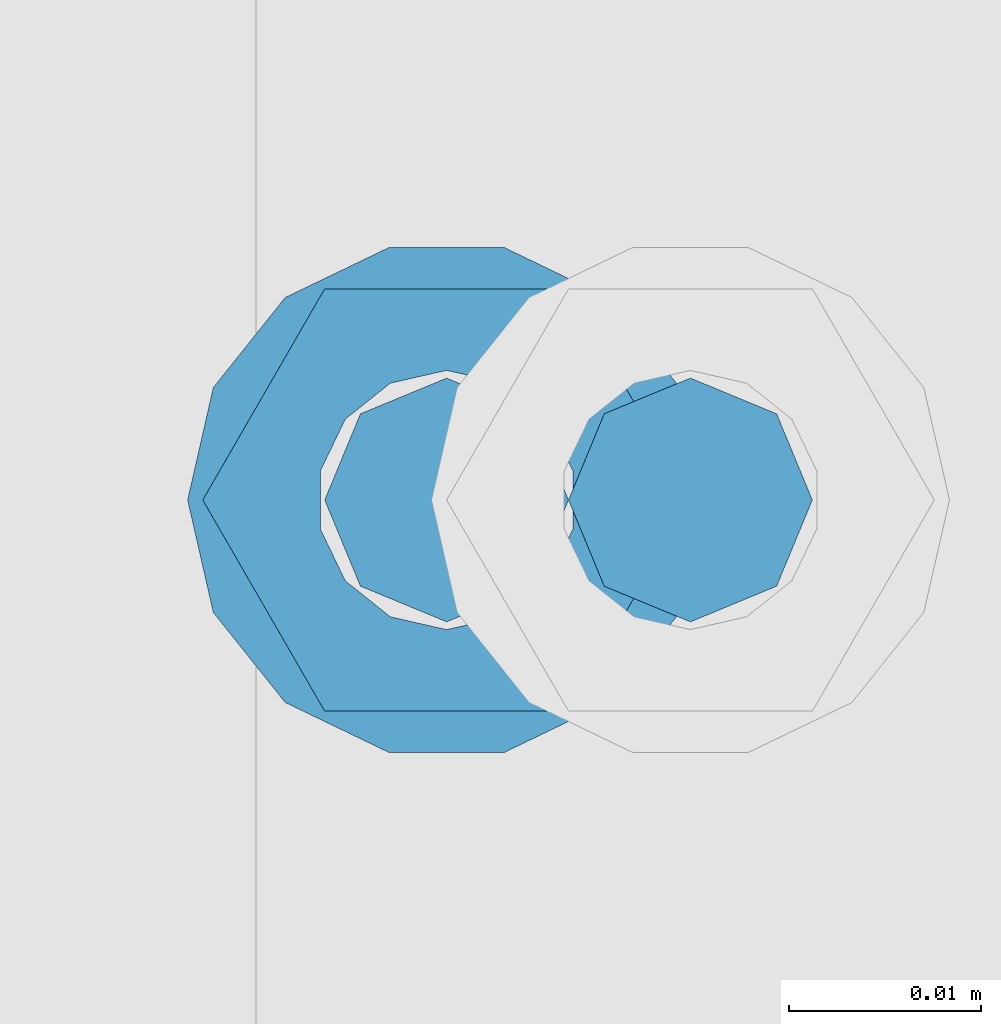
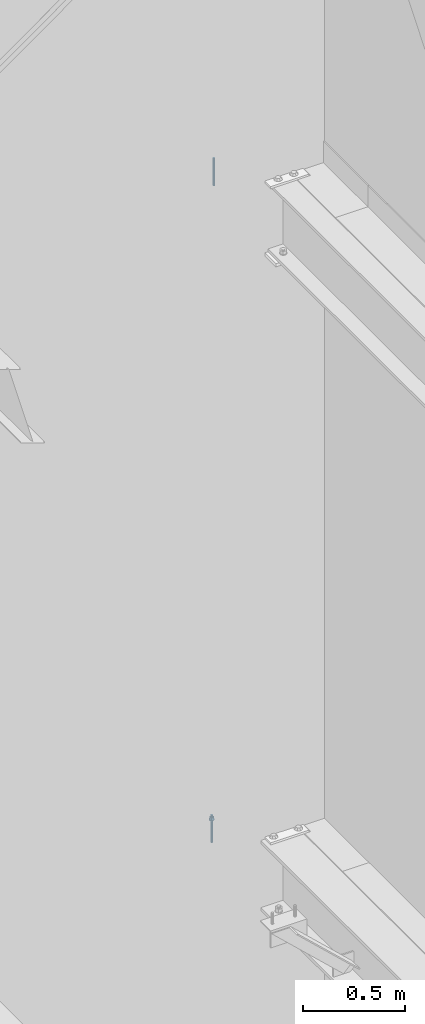
# One storey, part 573 of 1179: 2 columns, 2 elements without a shape of their own.
"""IFC2X3 building model written with IfcOpenShell, lengths in millimetres."""

import ifcopenshell
import ifcopenshell.guid

model = None  # the IFC model being written
_history = None  # IfcOwnerHistory: only IFC2X3 demands one
_inside = {}  # id of a spatial element -> (the spatial element, [elements in it])
_under = {}  # id of a project, library or spatial element -> (it, [spatial elements below it])
_declared = {}  # id of a project -> (the project, [libraries it declares])
_typed = {}  # id of a type object -> (the type object, [elements of that type])
_made_of = {}  # id of a material, layer set ... -> (it, [elements and type objects made of it])


def new_model(schema):
    """Start an empty IFC model of exactly this schema.

    Asked for "IFC4X3", IfcOpenShell would pick the latest addendum, in which some entities
    have other attributes; the version numbers below select the first issue.
    IFC2X3 requires an IfcOwnerHistory on every rooted entity: one is made here for all.
    """
    global model, _history
    if schema == "IFC4X3":
        model = ifcopenshell.file(schema_version=(4, 3, 0, 0))
    else:
        model = ifcopenshell.file(schema=schema)
    _inside.clear()
    _under.clear()
    _declared.clear()
    _typed.clear()
    _made_of.clear()
    _history = None
    if model.schema == "IFC2X3":
        org = make("IfcOrganization", Name="unknown")
        user = make(
            "IfcPersonAndOrganization",
            ThePerson=make("IfcPerson", FamilyName="unknown"),
            TheOrganization=org,
        )
        app = make(
            "IfcApplication",
            ApplicationDeveloper=org,
            Version="unknown",
            ApplicationFullName="unknown",
            ApplicationIdentifier="unknown",
        )
        _history = make(
            "IfcOwnerHistory",
            OwningUser=user,
            OwningApplication=app,
            ChangeAction="ADDED",
            CreationDate=0,
        )
    return model


def make(cls, **values):
    """One entity of the class cls with the attributes given. An attribute that is None is left unset."""
    return model.create_entity(
        cls, **{name: value for name, value in values.items() if value is not None}
    )


def rooted(cls, **values):
    """An entity with a GlobalId (a new one), such as an element, a storey or a relation."""
    return make(cls, GlobalId=ifcopenshell.guid.new(), OwnerHistory=_history, **values)


def si_unit(unit_type, name, prefix=None):
    """IfcSIUnit, for example si_unit("LENGTHUNIT", "METRE", prefix="MILLI")."""
    return make("IfcSIUnit", UnitType=unit_type, Prefix=prefix, Name=name)


def assignment(units):
    """IfcUnitAssignment: the units of a project."""
    return None if units is None else make("IfcUnitAssignment", Units=units)


def point(xyz):
    """IfcCartesianPoint."""
    return None if xyz is None else make("IfcCartesianPoint", Coordinates=xyz)


def direction(xyz):
    """IfcDirection."""
    return None if xyz is None else make("IfcDirection", DirectionRatios=xyz)


def frame(location, z_axis=None, x_axis=None):
    """IfcAxis2Placement3D, a coordinate frame: its origin and axes. An axis left out is left unset."""
    return make(
        "IfcAxis2Placement3D",
        Location=point(location),
        Axis=direction(z_axis),
        RefDirection=direction(x_axis),
    )


def origin_with_axes():
    """The frame at (0, 0, 0) with the z axis (0, 0, 1) and the x axis (1, 0, 0) written out."""
    return frame((0.0, 0.0, 0.0), z_axis=(0.0, 0.0, 1.0), x_axis=(1.0, 0.0, 0.0))


def place(relative_to, where):
    """IfcLocalPlacement: puts the frame where relative to a parent placement (None: the world)."""
    return make(
        "IfcLocalPlacement", PlacementRelTo=relative_to, RelativePlacement=where
    )


def context(
    kind, dimensions, precision=None, world=None, true_north=None, identifier=None
):
    """IfcGeometricRepresentationContext, for example the 3D "Model" context."""
    return make(
        "IfcGeometricRepresentationContext",
        ContextIdentifier=identifier,
        ContextType=kind,
        CoordinateSpaceDimension=dimensions,
        Precision=precision,
        WorldCoordinateSystem=world,
        TrueNorth=true_north,
    )


def subcontext(parent, identifier, kind, view, scale=None):
    """IfcGeometricRepresentationSubContext, for example "Body" below "Model"."""
    return make(
        "IfcGeometricRepresentationSubContext",
        ContextIdentifier=identifier,
        ContextType=kind,
        ParentContext=parent,
        TargetScale=scale,
        TargetView=view,
    )


def project(units=None, contexts=None):
    """IfcProject with its units and contexts."""
    return rooted(
        "IfcProject",
        Name="project",
        RepresentationContexts=contexts,
        UnitsInContext=assignment(units),
    )


def spatial(cls, under=None, at=None, **own):
    """A site, building, storey or space (cls), placed at a placement, below another one or the project."""
    s = rooted(cls, ObjectPlacement=at, **own)
    if under is not None:
        _under.setdefault(under.id(), (under, []))[1].append(s)
    return s


def faces_of(points, faces, orient=None, outer=None):
    """IfcFace entities. A face is a list of loops; a loop is a list of indices into points, from 0.

    orient and outer hold one flag for each loop. By default every Orientation is true, the
    first loop of a face is its IfcFaceOuterBound and the others are IfcFaceBound.
    """
    made = []
    for i, loops in enumerate(faces):
        bounds = []
        for j, loop in enumerate(loops):
            is_outer = j == 0 if outer is None else outer[i][j]
            bounds.append(
                make(
                    "IfcFaceOuterBound" if is_outer else "IfcFaceBound",
                    Bound=make("IfcPolyLoop", Polygon=[points[k] for k in loop]),
                    Orientation=True if orient is None else orient[i][j],
                )
            )
        made.append(make("IfcFace", Bounds=bounds))
    return made


def faceted_brep(points, faces, orient=None, outer=None, voids=None):
    """IfcFacetedBrep: a solid bounded by flat faces; with voids (closed shells), ...WithVoids."""
    shared = [point(p) for p in points]
    hull = make("IfcClosedShell", CfsFaces=faces_of(shared, faces, orient, outer))
    if voids is None:
        return make("IfcFacetedBrep", Outer=hull)
    return make(
        "IfcFacetedBrepWithVoids",
        Outer=hull,
        Voids=[
            make(cls, CfsFaces=faces_of(shared, fs, o, b)) for cls, fs, o, b in voids
        ],
    )


def shape(context_of_items, identifier, shape_type, items):
    """IfcShapeRepresentation: the items that make up one representation, for example the "Body"."""
    return make(
        "IfcShapeRepresentation",
        ContextOfItems=context_of_items,
        RepresentationIdentifier=identifier,
        RepresentationType=shape_type,
        Items=items,
    )


def material(Name=None, Category=None):
    """IfcMaterial."""
    return make("IfcMaterial", Name=Name, Category=Category)


def made_of(thing, what):
    """Note that an element or type object is made of a material, layer set ...; save() writes the relation."""
    if what is not None:
        _made_of.setdefault(what.id(), (what, []))[1].append(thing)
    return thing


def type_object(cls, material=None, **own):
    """A type object (cls), such as IfcWallType, which elements share."""
    return made_of(rooted(cls, **own), material)


def element(
    cls,
    number,
    at=None,
    inside=None,
    cuts=None,
    type_object=None,
    material=None,
    context=None,
    identifier="Body",
    shape_type=None,
    held_by="IfcProductDefinitionShape",
    body=None,
    shapes=None,
    **own,
):
    """One element of the class cls, such as IfcWall. Its Tag is "e" and its number.

    at: its placement. inside: the storey or other place that contains it. cuts: it is an
    opening in that element (IfcRelVoidsElement). A single representation is given by context,
    identifier, shape_type and body (its items); several are given by shapes. held_by: the class
    of the entity that holds the representations. save() writes the other relations.
    """
    e = rooted(cls, Tag="e%d" % number, ObjectPlacement=at, **own)
    if body is not None:
        shapes = [shape(context, identifier, shape_type, body)]
    if shapes is not None:
        e.Representation = make(held_by, Representations=shapes)
    if inside is not None:
        _inside.setdefault(inside.id(), (inside, []))[1].append(e)
    if cuts is not None:
        rooted(
            "IfcRelVoidsElement", RelatingBuildingElement=cuts, RelatedOpeningElement=e
        )
    if type_object is not None:
        _typed.setdefault(type_object.id(), (type_object, []))[1].append(e)
    return made_of(e, material)


def aggregate(whole, parts):
    """IfcRelAggregates: a whole, such as a stair, and the parts it consists of."""
    return rooted("IfcRelAggregates", RelatingObject=whole, RelatedObjects=parts)


def save(model, path):
    """Write the relations noted so far, then the file.

    IfcRelAggregates (storeys below a building ...), IfcRelContainedInSpatialStructure (elements
    in a storey), IfcRelDefinesByType, IfcRelAssociatesMaterial and IfcRelDeclares: one each for
    every whole, place, type object, material and project.
    """
    for whole, parts in _under.values():
        aggregate(whole, parts)
    for where, things in _inside.values():
        rooted(
            "IfcRelContainedInSpatialStructure",
            RelatedElements=things,
            RelatingStructure=where,
        )
    for kind, things in _typed.values():
        rooted("IfcRelDefinesByType", RelatedObjects=things, RelatingType=kind)
    for what, things in _made_of.values():
        rooted("IfcRelAssociatesMaterial", RelatedObjects=things, RelatingMaterial=what)
    for by, libraries in _declared.values():
        rooted("IfcRelDeclares", RelatingContext=by, RelatedDefinitions=libraries)
    model.write(path)


model = new_model("IFC2X3")

# Units and contexts
model_context = context("Model", 3, precision=1e-05, world=origin_with_axes())
body_context = subcontext(model_context, "Body", "Model", "MODEL_VIEW")
ifc_project = project(units=[si_unit("LENGTHUNIT", "METRE", prefix="MILLI"), si_unit("AREAUNIT", "SQUARE_METRE"), si_unit("VOLUMEUNIT", "CUBIC_METRE"), si_unit("MASSUNIT", "GRAM", prefix="KILO"), si_unit("TIMEUNIT", "SECOND"), si_unit("PLANEANGLEUNIT", "RADIAN"), si_unit("SOLIDANGLEUNIT", "STERADIAN"), si_unit("THERMODYNAMICTEMPERATUREUNIT", "DEGREE_CELSIUS"), si_unit("LUMINOUSINTENSITYUNIT", "LUMEN")], contexts=[model_context])

# Site, building, storey
site_placement = place(None, origin_with_axes())
site = spatial("IfcSite", under=ifc_project, at=site_placement, CompositionType="ELEMENT")
building_placement = place(site_placement, origin_with_axes())
building = spatial("IfcBuilding", under=site, at=building_placement, Name="Undefined", CompositionType="ELEMENT")
storey_placement = place(building_placement, origin_with_axes())
storey = spatial("IfcBuildingStorey", under=building, at=storey_placement, Name="Undefined", CompositionType="ELEMENT", Elevation=0.0)

# Assembly, column
assembly_1_placement = place(storey_placement, origin_with_axes())
assembly_1 = element("IfcElementAssembly", 1, at=assembly_1_placement, inside=storey, Name="BEAM", AssemblyPlace="NOTDEFINED", PredefinedType="RIGID_FRAME")
ifc_material = material(Name="STEEL/A307")
column_type = type_object("IfcColumnType", PredefinedType="NOTDEFINED")
column_1_placement = place(assembly_1_placement, frame((23974.821875, 37985.7, 8013.7), z_axis=(0.0, 1.0, 0.0), x_axis=(0.0, 0.0, 1.0)))
column_1 = element("IfcColumn", 2, at=column_1_placement, type_object=column_type, material=ifc_material, Name="THREADED ROD", context=body_context, shape_type="Brep", body=[
    faceted_brep([(0.0, -6.34999999999854, 0.0), (0.0, -4.49012806053361, -4.49012806053452), (163.512500000001, -4.49012806053361, -4.49012806053452), (163.512500000001, -6.34999999999854, 0.0), (0.0, 0.0, -6.34999999999991), (163.512500000001, 0.0, -6.35000000000036), (0.0, 4.49012806053361, -4.49012806053452), (163.512500000001, 4.49012806053361, -4.49012806053452), (0.0, 6.34999999999854, 0.0), (163.512500000001, 6.34999999999854, 0.0), (0.0, 4.49012806053361, 4.49012806053452), (163.512500000001, 4.49012806053361, 4.49012806053452), (0.0, 0.0, 6.34999999999991), (163.512500000001, 0.0, 6.35000000000036), (0.0, -4.49012806053361, 4.49012806053452), (163.512500000001, -4.49012806053361, 4.49012806053452)], [[[0, 1, 2, 3]], [[1, 4, 5, 2]], [[4, 6, 7, 5]], [[6, 8, 9, 7]], [[8, 10, 11, 9]], [[10, 12, 13, 11]], [[12, 14, 15, 13]], [[14, 0, 3, 15]], [[5, 7, 9, 11, 13, 15, 3, 2]], [[14, 12, 10, 8, 6, 4, 1, 0]]]),
])
aggregate(assembly_1, [column_1])

assembly_2_placement = place(storey_placement, origin_with_axes())
assembly_2 = element("IfcElementAssembly", 3, at=assembly_2_placement, inside=storey, Name="BEAM", AssemblyPlace="NOTDEFINED", PredefinedType="RIGID_FRAME")
column_2_placement = place(assembly_2_placement, frame((23962.121875, 37985.7, 4102.1), z_axis=(0.0, 1.0, 0.0), x_axis=(0.0, 0.0, 1.0)))
column_2 = element("IfcColumn", 4, at=column_2_placement, type_object=column_type, material=ifc_material, Name="THREADED ROD", context=body_context, shape_type="Brep", body=[
    faceted_brep([(0.0, -4.49012806053361, 4.49012806053452), (0.0, -6.34999999999854, 0.0), (163.512500000001, -6.34999999999854, 0.0), (163.512500000001, -4.49012806053361, 4.49012806053452), (0.0, 0.0, 6.34999999999991), (0.0, 4.49012806053361, 4.49012806053452), (0.0, 6.34999999999854, 0.0), (0.0, 4.49012806053361, -4.49012806053452), (0.0, 0.0, -6.34999999999991), (0.0, -4.49012806053361, -4.49012806053452), (163.512500000001, 0.0, 6.35000000000036), (163.512500000001, 4.49012806053361, 4.49012806053452), (163.512500000001, 6.34999999999854, 0.0), (163.512500000001, 4.49012806053361, -4.49012806053452), (163.512500000001, 0.0, -6.35000000000036), (163.512500000001, -4.49012806053361, -4.49012806053452), (133.349999999999, -12.1540698217887, -5.85309154138668), (133.349999999999, -8.41087728436833, -10.5469065195502), (138.112499999999, -8.41087728436833, -10.5469065195502), (138.112499999999, -12.1540698217887, -5.85309154138668), (133.349999999999, -3.00180734814057, -13.1517773121886), (138.112499999999, -3.00180734814057, -13.1517773121886), (133.349999999999, 3.00180734814057, -13.1517773121886), (138.112499999999, 3.00180734814057, -13.1517773121886), (133.349999999999, 8.41087728436833, -10.5469065195502), (138.112499999999, 8.41087728436833, -10.5469065195502), (133.349999999999, 12.1540698217887, -5.85309154138668), (138.112499999999, 12.1540698217887, -5.85309154138668), (133.349999999999, 13.4899997711182, 0.0), (138.112499999999, 13.4899997711182, 0.0), (133.349999999999, 12.1540698217887, 5.85309154138668), (138.112499999999, 12.1540698217887, 5.85309154138668), (133.349999999999, 8.41087728436833, 10.5469065195502), (138.112499999999, 8.41087728436833, 10.5469065195502), (133.349999999999, 3.00180734814057, 13.1517773121886), (138.112499999999, 3.00180734814057, 13.1517773121886), (133.349999999999, -3.00180734814057, 13.1517773121886), (138.112499999999, -3.00180734814057, 13.1517773121886), (133.349999999999, -8.41087728436833, 10.5469065195502), (138.112499999999, -8.41087728436833, 10.5469065195502), (133.349999999999, -12.1540698217887, 5.85309154138668), (138.112499999999, -12.1540698217887, 5.85309154138668), (133.349999999999, -13.4899997711182, 0.0), (138.112499999999, -13.4899997711182, 0.0), (138.112499999999, -12.6999998092651, 0.0), (138.112499999999, -6.34999990463257, 11.0), (138.112499999999, 6.34999990463257, 11.0), (138.112499999999, 12.6999998092651, 0.0), (138.112499999999, 6.34999990463257, -11.0), (138.112499999999, -6.34999990463257, -11.0), (133.349999999999, -2.92871523904432, 6.0815398583436), (133.349999999999, -5.27736250665839, 4.20855616254994), (133.349999999999, -6.58076340722801, 1.50201630420634), (133.349999999999, -6.58076340722801, -1.50201630420634), (133.349999999999, -5.27736250665839, -4.20855616254994), (133.349999999999, -2.92871523904432, -6.0815398583436), (133.349999999999, 0.0, -6.75), (133.349999999999, 2.92871523904432, -6.0815398583436), (133.349999999999, 5.27736250665839, -4.20855616254994), (133.349999999999, 6.58076340722801, -1.50201630420634), (133.349999999999, 6.58076340722801, 1.50201630420634), (133.349999999999, 5.27736250665839, 4.20855616254994), (133.349999999999, 2.92871523904432, 6.0815398583436), (133.349999999999, 0.0, 6.75), (150.812499999999, -2.92871523904432, 6.0815398583436), (150.812499999999, 0.0, 6.75), (150.812499999999, -5.27736250665839, 4.20855616254994), (150.812499999999, -6.58076340722801, 1.50201630420634), (150.812499999999, -5.27736250665839, -4.20855616254994), (150.812499999999, -6.58076340722801, -1.50201630420634), (150.812499999999, -2.92871523904432, -6.0815398583436), (150.812499999999, 0.0, -6.75), (150.812499999999, 2.92871523904432, -6.0815398583436), (150.812499999999, 5.27736250665839, -4.20855616254994), (150.812499999999, 6.58076340722801, -1.50201630420634), (150.812499999999, 5.27736250665839, 4.20855616254994), (150.812499999999, 6.58076340722801, 1.50201630420634), (150.812499999999, 2.92871523904432, 6.0815398583436), (150.812499999999, -12.6999998092651, 0.0), (150.812499999999, -6.34999990463257, 11.0), (150.812499999999, 6.34999990463257, -11.0), (150.812499999999, -6.34999990463257, -11.0), (150.812499999999, 12.6999998092651, 0.0), (150.812499999999, 6.34999990463257, 11.0)], [[[0, 1, 2, 3]], [[0, 4, 5, 6, 7, 8, 9, 1]], [[5, 4, 10, 11]], [[6, 5, 11, 12]], [[7, 6, 12, 13]], [[8, 7, 13, 14]], [[9, 8, 14, 15]], [[1, 9, 15, 2]], [[14, 13, 12, 11, 10, 3, 2, 15]], [[4, 0, 3, 10]], [[16, 17, 18, 19]], [[17, 20, 21, 18]], [[20, 22, 23, 21]], [[22, 24, 25, 23]], [[24, 26, 27, 25]], [[26, 28, 29, 27]], [[28, 30, 31, 29]], [[30, 32, 33, 31]], [[32, 34, 35, 33]], [[34, 36, 37, 35]], [[36, 38, 39, 37]], [[38, 40, 41, 39]], [[40, 42, 43, 41]], [[18, 21, 23, 25, 27, 29, 31, 33, 35, 37, 39, 41, 43, 19], [44, 45, 46, 47, 48, 49]], [[42, 16, 19, 43]], [[40, 38, 36, 34, 32, 30, 28, 26, 24, 22, 20, 17, 16, 42], [50, 51, 52, 53, 54, 55, 56, 57, 58, 59, 60, 61, 62, 63]], [[64, 50, 63, 65]], [[66, 51, 50, 64]], [[67, 52, 51, 66]], [[68, 54, 53, 69]], [[70, 55, 54, 68]], [[71, 56, 55, 70]], [[72, 57, 56, 71]], [[73, 58, 57, 72]], [[74, 59, 58, 73]], [[75, 61, 60, 76]], [[77, 62, 61, 75]], [[77, 65, 63, 62]], [[78, 79, 45, 44]], [[80, 81, 49, 48]], [[82, 80, 48, 47]], [[83, 82, 47, 46]], [[79, 83, 46, 45]], [[81, 78, 44, 49]], [[53, 52, 67, 69]], [[60, 59, 74, 76]], [[80, 82, 83, 79, 78, 81], [75, 76, 74, 73, 72, 71, 70, 68, 69, 67, 66, 64, 65, 77]]]),
])
aggregate(assembly_2, [column_2])

save(model, "model.ifc")
